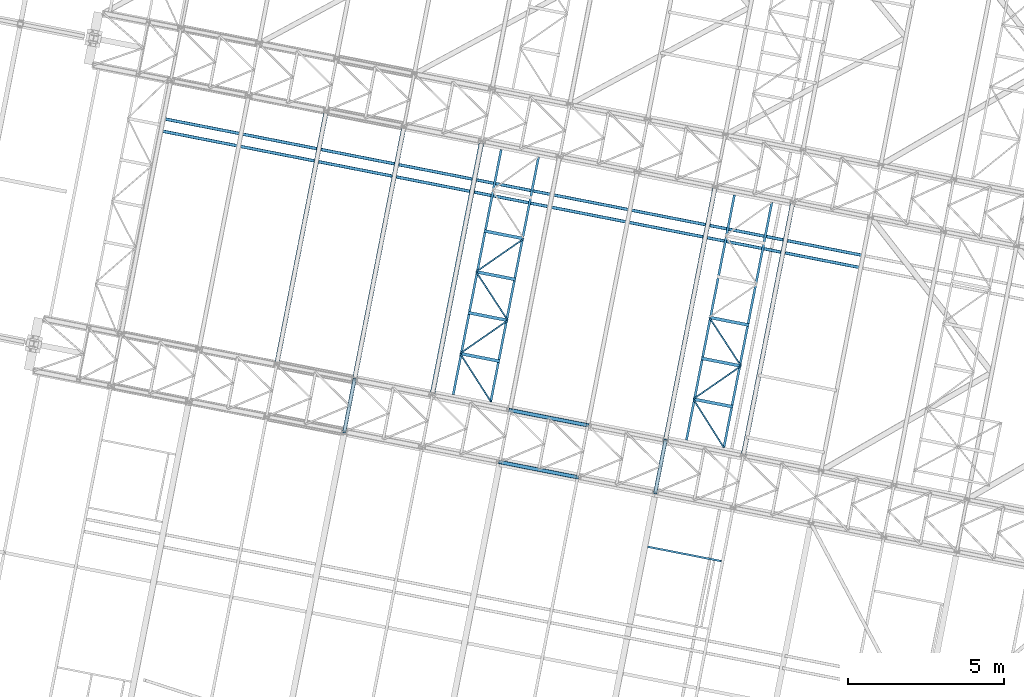
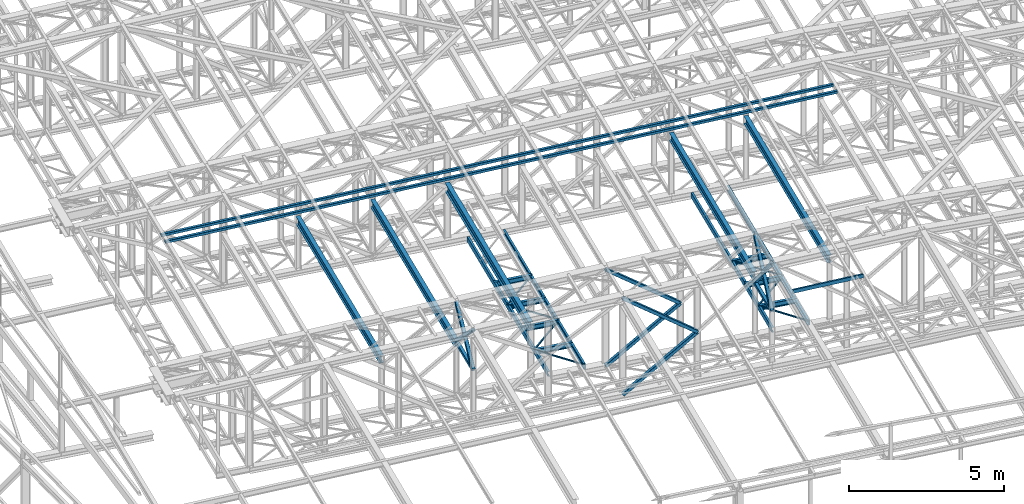
# One storey, part 44 of 215: 28 beams, 8 members, 36 elements without a shape of their own.
"""IFC2X3 building model written with IfcOpenShell, lengths in millimetres."""

from ifc_helpers import new_model, si_unit, frame, origin_with_axes, origin_2d_with_axis, place, context, subcontext, project, spatial, hollow_rectangle, i_section, u_section, extrude, material, type_object, element, aggregate, save


model = new_model("IFC2X3")

# Units and contexts
model_context = context("Model", 3, precision=1e-05, world=origin_with_axes())
body_context = subcontext(model_context, "Body", "Model", "MODEL_VIEW")
ifc_project = project(units=[si_unit("LENGTHUNIT", "METRE", prefix="MILLI"), si_unit("AREAUNIT", "SQUARE_METRE"), si_unit("VOLUMEUNIT", "CUBIC_METRE"), si_unit("MASSUNIT", "GRAM", prefix="KILO"), si_unit("TIMEUNIT", "SECOND"), si_unit("PLANEANGLEUNIT", "RADIAN"), si_unit("SOLIDANGLEUNIT", "STERADIAN"), si_unit("THERMODYNAMICTEMPERATUREUNIT", "DEGREE_CELSIUS"), si_unit("LUMINOUSINTENSITYUNIT", "LUMEN")], contexts=[model_context])

# Site, building, storey
site_placement = place(None, origin_with_axes())
site = spatial("IfcSite", under=ifc_project, at=site_placement, CompositionType="ELEMENT")
building_placement = place(site_placement, origin_with_axes())
building = spatial("IfcBuilding", under=site, at=building_placement, Name="Undefined", CompositionType="ELEMENT")
storey_placement = place(building_placement, origin_with_axes())
storey = spatial("IfcBuildingStorey", under=building, at=storey_placement, Name="Undefined", CompositionType="ELEMENT", Elevation=0.0)

# Assembly, beam
assembly_1_placement = place(storey_placement, origin_with_axes())
assembly_1 = element("IfcElementAssembly", 1, at=assembly_1_placement, inside=storey, Name="Steel Assembly", AssemblyPlace="NOTDEFINED", PredefinedType="RIGID_FRAME")
ifc_material_1 = material(Name="STEEL/S275JR")
beam_type_1 = type_object("IfcBeamType", PredefinedType="NOTDEFINED")
beam_1_placement = place(assembly_1_placement, frame((52219.5197880456, 20363.2867961429, 10796.000001022), z_axis=(0.981422364268518, -0.191859461052493, -0.000300197000082615), x_axis=(0.191859470081235, 0.981422408415534, 0.0)))
beam_1 = element("IfcBeam", 2, at=beam_1_placement, type_object=beam_type_1, material=ifc_material_1, context=body_context, shape_type="SweptSolid", body=[
    extrude(hollow_rectangle(XDim=120.0, YDim=120.0, WallThickness=5.0, InnerFilletRadius=5.0, OuterFilletRadius=10.0, at=origin_2d_with_axis()), frame((1699.99999941724, 1.81898940354586e-12, 0.0), z_axis=(-1.0, 0.0, 0.0), x_axis=(-6.93889390390723e-18, -1.0, -3.46944695195361e-18)), (0.0, 0.0, 1.0), 1700.0),
])
aggregate(assembly_1, [beam_1])

assembly_2_placement = place(storey_placement, origin_with_axes())
assembly_2 = element("IfcElementAssembly", 3, at=assembly_2_placement, inside=storey, Name="Steel Assembly", AssemblyPlace="NOTDEFINED", PredefinedType="RIGID_FRAME")
beam_2_placement = place(assembly_2_placement, frame((62204.4132373242, 18411.3277748122, 10796.0000009114), z_axis=(0.981422364268518, -0.191859461052493, -0.000300197000082615), x_axis=(0.191859470081235, 0.981422408415534, 0.0)))
beam_2 = element("IfcBeam", 4, at=beam_2_placement, type_object=beam_type_1, material=ifc_material_1, context=body_context, shape_type="SweptSolid", body=[
    extrude(hollow_rectangle(XDim=120.0, YDim=120.0, WallThickness=5.0, InnerFilletRadius=5.0, OuterFilletRadius=10.0, at=origin_2d_with_axis()), frame((1699.99999941724, 1.81898940354586e-12, 0.0), z_axis=(-1.0, 0.0, 0.0), x_axis=(-6.93889390390723e-18, -1.0, -3.46944695195361e-18)), (0.0, 0.0, 1.0), 1700.0),
])
aggregate(assembly_2, [beam_2])

assembly_3_placement = place(storey_placement, origin_with_axes())
assembly_3 = element("IfcElementAssembly", 5, at=assembly_3_placement, inside=storey, Name="Steel Assembly", AssemblyPlace="NOTDEFINED", PredefinedType="RIGID_FRAME")
beam_type_2 = type_object("IfcBeamType", PredefinedType="NOTDEFINED")
beam_3_placement = place(assembly_3_placement, frame((46407.8596790011, 30413.6755981437, 12020.0732186294), z_axis=(0.0304072880144601, -0.0059443590028274, -0.99951991547525), x_axis=(0.980943093982696, -0.191809039996616, 0.0309828749994535)))
beam_3 = element("IfcBeam", 6, at=beam_3_placement, type_object=beam_type_2, material=ifc_material_1, context=body_context, shape_type="SweptSolid", body=[
    extrude(hollow_rectangle(XDim=100.0, YDim=100.0, WallThickness=5.0, InnerFilletRadius=5.0, OuterFilletRadius=10.0, at=origin_2d_with_axis()), frame((22902.816814498, -7.45768641912541e-12, 0.0), z_axis=(-1.0, 0.0, 0.0), x_axis=(-6.93889390390723e-18, -1.0, -3.46944695195361e-18)), (0.0, 0.0, 1.0), 22902.8),
])
aggregate(assembly_3, [beam_3])

assembly_4_placement = place(storey_placement, origin_with_axes())
assembly_4 = element("IfcElementAssembly", 7, at=assembly_4_placement, inside=storey, Name="Steel Assembly", AssemblyPlace="NOTDEFINED", PredefinedType="RIGID_FRAME")
beam_4_placement = place(assembly_4_placement, frame((46331.0992129724, 30021.1098955661, 12020.0732185902), z_axis=(0.0304072880144601, -0.0059443590028274, -0.99951991547525), x_axis=(0.980943093982696, -0.191809039996616, 0.0309828749994535)))
beam_4 = element("IfcBeam", 8, at=beam_4_placement, type_object=beam_type_2, material=ifc_material_1, context=body_context, shape_type="SweptSolid", body=[
    extrude(hollow_rectangle(XDim=100.0, YDim=100.0, WallThickness=5.0, InnerFilletRadius=5.0, OuterFilletRadius=10.0, at=origin_2d_with_axis()), frame((22902.816814498, -7.45768641912541e-12, 0.0), z_axis=(-1.0, 0.0, 0.0), x_axis=(-6.93889390390723e-18, -1.0, -3.46944695195361e-18)), (0.0, 0.0, 1.0), 22902.8),
])
aggregate(assembly_4, [beam_4])

assembly_5_placement = place(storey_placement, origin_with_axes())
assembly_5 = element("IfcElementAssembly", 9, at=assembly_5_placement, inside=storey, Name="Steel Assembly", AssemblyPlace="NOTDEFINED", PredefinedType="RIGID_FRAME")
beam_type_3 = type_object("IfcBeamType", PredefinedType="NOTDEFINED")
beam_5_placement = place(assembly_5_placement, frame((55935.9362443765, 22873.5578027665, 8745.0), z_axis=(0.0, 0.0, -1.0), x_axis=(0.538159780693369, -0.842842838519771, 0.0)))
beam_5 = element("IfcBeam", 10, at=beam_5_placement, type_object=beam_type_3, material=ifc_material_1, context=body_context, shape_type="SweptSolid", body=[
    extrude(hollow_rectangle(XDim=50.0, YDim=50.0, WallThickness=3.0, InnerFilletRadius=3.0, OuterFilletRadius=6.0, at=origin_2d_with_axis()), frame((1829.52275494059, 0.0, 0.0), z_axis=(-1.0, 0.0, 0.0), x_axis=(-6.93889390390723e-18, -1.0, -3.46944695195361e-18)), (0.0, 0.0, 1.0), 1829.5),
])
aggregate(assembly_5, [beam_5])

assembly_6_placement = place(storey_placement, origin_with_axes())
assembly_6 = element("IfcElementAssembly", 11, at=assembly_6_placement, inside=storey, Name="Steel Assembly", AssemblyPlace="NOTDEFINED", PredefinedType="RIGID_FRAME")
beam_6_placement = place(assembly_6_placement, frame((57467.6126150394, 23935.7198777264, 8745.0), z_axis=(0.0, 0.0, -1.0), x_axis=(-0.821747337666729, -0.569852009768889, 0.0)))
beam_6 = element("IfcBeam", 12, at=beam_6_placement, type_object=beam_type_3, material=ifc_material_1, context=body_context, shape_type="SweptSolid", body=[
    extrude(hollow_rectangle(XDim=50.0, YDim=50.0, WallThickness=3.0, InnerFilletRadius=3.0, OuterFilletRadius=6.0, at=origin_2d_with_axis()), frame((1863.9261728348, 1.03468687664132e-13, 0.0), z_axis=(-1.0, 0.0, 0.0), x_axis=(-6.93889390390723e-18, -1.0, -3.46944695195361e-18)), (0.0, 0.0, 1.0), 1863.9),
])
aggregate(assembly_6, [beam_6])

assembly_7_placement = place(storey_placement, origin_with_axes())
assembly_7 = element("IfcElementAssembly", 13, at=assembly_7_placement, inside=storey, Name="Steel Assembly", AssemblyPlace="NOTDEFINED", PredefinedType="RIGID_FRAME")
beam_7_placement = place(assembly_7_placement, frame((56449.5868708495, 25497.0795917, 8745.0), z_axis=(0.0, 0.0, -1.0), x_axis=(0.54617279813842, -0.837672534212295, 0.0)))
beam_7 = element("IfcBeam", 14, at=beam_7_placement, type_object=beam_type_3, material=ifc_material_1, context=body_context, shape_type="SweptSolid", body=[
    extrude(hollow_rectangle(XDim=50.0, YDim=50.0, WallThickness=3.0, InnerFilletRadius=3.0, OuterFilletRadius=6.0, at=origin_2d_with_axis()), frame((1863.92611772227, 0.0, 1.81898940354586e-12), z_axis=(-1.0, 0.0, 0.0), x_axis=(-6.93889390390723e-18, -1.0, -3.46944695195361e-18)), (0.0, 0.0, 1.0), 1863.9),
])
aggregate(assembly_7, [beam_7])

assembly_8_placement = place(storey_placement, origin_with_axes())
assembly_8 = element("IfcElementAssembly", 15, at=assembly_8_placement, inside=storey, Name="Steel Assembly", AssemblyPlace="NOTDEFINED", PredefinedType="RIGID_FRAME")
beam_8_placement = place(assembly_8_placement, frame((57980.8309690882, 26558.5769034106, 8745.0), z_axis=(0.0, 0.0, -1.0), x_axis=(-0.821839062095499, -0.5697197170662, 0.0)))
beam_8 = element("IfcBeam", 16, at=beam_8_placement, type_object=beam_type_3, material=ifc_material_1, context=body_context, shape_type="SweptSolid", body=[
    extrude(hollow_rectangle(XDim=50.0, YDim=50.0, WallThickness=3.0, InnerFilletRadius=3.0, OuterFilletRadius=6.0, at=origin_2d_with_axis()), frame((1863.19216164478, 0.0, 0.0), z_axis=(-1.0, 0.0, 0.0), x_axis=(-6.93889390390723e-18, -1.0, -3.46944695195361e-18)), (0.0, 0.0, 1.0), 1863.2),
])
aggregate(assembly_8, [beam_8])

assembly_9_placement = place(storey_placement, origin_with_axes())
assembly_9 = element("IfcElementAssembly", 17, at=assembly_9_placement, inside=storey, Name="Steel Assembly", AssemblyPlace="NOTDEFINED", PredefinedType="RIGID_FRAME")
beam_9_placement = place(assembly_9_placement, frame((63422.3085909244, 21410.0377418613, 8745.0), z_axis=(0.0, 0.0, -1.0), x_axis=(0.53287875690889, -0.846191603855319, 0.0)))
beam_9 = element("IfcBeam", 18, at=beam_9_placement, type_object=beam_type_3, material=ifc_material_1, context=body_context, shape_type="SweptSolid", body=[
    extrude(hollow_rectangle(XDim=50.0, YDim=50.0, WallThickness=3.0, InnerFilletRadius=3.0, OuterFilletRadius=6.0, at=origin_2d_with_axis()), frame((1835.47534354543, 0.0, 0.0), z_axis=(-1.0, 0.0, 0.0), x_axis=(-6.93889390390723e-18, -1.0, -3.46944695195361e-18)), (0.0, 0.0, 1.0), 1835.5),
])
aggregate(assembly_9, [beam_9])

assembly_10_placement = place(storey_placement, origin_with_axes())
assembly_10 = element("IfcElementAssembly", 19, at=assembly_10_placement, inside=storey, Name="Steel Assembly", AssemblyPlace="NOTDEFINED", PredefinedType="RIGID_FRAME")
beam_10_placement = place(assembly_10_placement, frame((64954.8968461689, 22472.0414317465, 8745.0), z_axis=(0.0, 0.0, -1.0), x_axis=(-0.821945876331178, -0.56956560322949, 0.0)))
beam_10 = element("IfcBeam", 20, at=beam_10_placement, type_object=beam_type_3, material=ifc_material_1, context=body_context, shape_type="SweptSolid", body=[
    extrude(hollow_rectangle(XDim=50.0, YDim=50.0, WallThickness=3.0, InnerFilletRadius=3.0, OuterFilletRadius=6.0, at=origin_2d_with_axis()), frame((1864.58536882556, 0.0, 0.0), z_axis=(-1.0, 0.0, 0.0), x_axis=(-6.93889390390723e-18, -1.0, -3.46944695195361e-18)), (0.0, 0.0, 1.0), 1864.6),
])
aggregate(assembly_10, [beam_10])

assembly_11_placement = place(storey_placement, origin_with_axes())
assembly_11 = element("IfcElementAssembly", 21, at=assembly_11_placement, inside=storey, Name="Steel Assembly", AssemblyPlace="NOTDEFINED", PredefinedType="RIGID_FRAME")
beam_11_placement = place(assembly_11_placement, frame((63935.9192699006, 24033.5673808455, 8745.0), z_axis=(0.0, 0.0, -1.0), x_axis=(0.546490170770853, -0.837465517648843, 0.0)))
beam_11 = element("IfcBeam", 22, at=beam_11_placement, type_object=beam_type_3, material=ifc_material_1, context=body_context, shape_type="SweptSolid", body=[
    extrude(hollow_rectangle(XDim=50.0, YDim=50.0, WallThickness=3.0, InnerFilletRadius=3.0, OuterFilletRadius=6.0, at=origin_2d_with_axis()), frame((1864.58536882556, 0.0, 0.0), z_axis=(-1.0, 0.0, 0.0), x_axis=(-6.93889390390723e-18, -1.0, -3.46944695195361e-18)), (0.0, 0.0, 1.0), 1864.6),
])
aggregate(assembly_11, [beam_11])

assembly_12_placement = place(storey_placement, origin_with_axes())
assembly_12 = element("IfcElementAssembly", 23, at=assembly_12_placement, inside=storey, Name="Steel Assembly", AssemblyPlace="NOTDEFINED", PredefinedType="RIGID_FRAME")
ifc_material_2 = material(Name="STEEL/S235JR")
beam_type_4 = type_object("IfcBeamType", Name="UPN140", PredefinedType="NOTDEFINED")
beam_12_placement = place(assembly_12_placement, frame((64320.2677545784, 16207.585553462, 12769.5771242344), z_axis=(-0.0304080349967745, 0.00594450299936818, 0.999519891893966), x_axis=(-0.980947279001733, 0.191787511000338, -0.0309836480000548)))
beam_12 = element("IfcBeam", 24, at=beam_12_placement, type_object=beam_type_4, material=ifc_material_2, ObjectType="UPN140", context=body_context, shape_type="SweptSolid", body=[
    extrude(u_section(Depth=140.0, FlangeWidth=60.0, WebThickness=7.0, FlangeThickness=10.0, FilletRadius=10.0, EdgeRadius=5.0, FlangeSlope=0.0798299857122373, at=origin_2d_with_axis()), frame((2404.26612991932, -3.62067344519824e-12, -8.34147379613389e-15), z_axis=(-1.0, 0.0, 0.0), x_axis=(-6.93889390390723e-18, -1.0, -3.46944695195361e-18)), (0.0, 0.0, 1.0), 2404.3),
])
aggregate(assembly_12, [beam_12])

assembly_13_placement = place(storey_placement, origin_with_axes())
assembly_13 = element("IfcElementAssembly", 25, at=assembly_13_placement, inside=storey, Name="Steel Assembly", AssemblyPlace="NOTDEFINED", PredefinedType="RIGID_FRAME")
beam_type_5 = type_object("IfcBeamType", Name="UPN200", PredefinedType="NOTDEFINED")
beam_13_placement = place(assembly_13_placement, frame((57255.4686469135, 29418.0296462488, 8670.00000003358), z_axis=(0.0, 0.0, -1.0), x_axis=(-0.192138740064459, -0.981367772329233, 0.0)))
beam_13 = element("IfcBeam", 26, at=beam_13_placement, type_object=beam_type_5, material=ifc_material_1, ObjectType="UPN200", context=body_context, shape_type="SweptSolid", body=[
    extrude(u_section(Depth=200.0, FlangeWidth=75.0, WebThickness=8.5, FlangeThickness=11.5, FilletRadius=11.5, EdgeRadius=6.0, FlangeSlope=0.0798299857122373, at=origin_2d_with_axis()), frame((8012.73300634067, 0.0, 0.0), z_axis=(-1.0, 0.0, 0.0), x_axis=(-6.93889390390723e-18, -1.0, -3.46944695195361e-18)), (0.0, 0.0, 1.0), 8012.7),
])
aggregate(assembly_13, [beam_13])

assembly_14_placement = place(storey_placement, origin_with_axes())
assembly_14 = element("IfcElementAssembly", 27, at=assembly_14_placement, inside=storey, Name="Steel Assembly", AssemblyPlace="NOTDEFINED", PredefinedType="RIGID_FRAME")
beam_14_placement = place(assembly_14_placement, frame((56918.1647920204, 21319.5700001863, 8670.00000000009), z_axis=(0.0, 0.0, -1.0), x_axis=(0.19178870802505, 0.981436239128188, 0.0)))
beam_14 = element("IfcBeam", 28, at=beam_14_placement, type_object=beam_type_5, material=ifc_material_1, ObjectType="UPN200", context=body_context, shape_type="SweptSolid", body=[
    extrude(u_section(Depth=200.0, FlangeWidth=75.0, WebThickness=8.5, FlangeThickness=11.5, FilletRadius=11.5, EdgeRadius=6.0, FlangeSlope=0.0798299857122373, at=origin_2d_with_axis()), frame((8019.9954338182, 0.0, 0.0), z_axis=(-1.0, 0.0, 0.0), x_axis=(-6.93889390390723e-18, -1.0, -3.46944695195361e-18)), (0.0, 0.0, 1.0), 8020.0),
])
aggregate(assembly_14, [beam_14])

assembly_15_placement = place(storey_placement, origin_with_axes())
assembly_15 = element("IfcElementAssembly", 29, at=assembly_15_placement, inside=storey, Name="Steel Assembly", AssemblyPlace="NOTDEFINED", PredefinedType="RIGID_FRAME")
beam_15_placement = place(assembly_15_placement, frame((64743.136689549, 27961.6571970074, 8670.00000003358), z_axis=(0.0, 0.0, -1.0), x_axis=(-0.192123795048203, -0.981370698246221, 0.0)))
beam_15 = element("IfcBeam", 30, at=beam_15_placement, type_object=beam_type_5, material=ifc_material_1, ObjectType="UPN200", context=body_context, shape_type="SweptSolid", body=[
    extrude(u_section(Depth=200.0, FlangeWidth=75.0, WebThickness=8.5, FlangeThickness=11.5, FilletRadius=11.5, EdgeRadius=6.0, FlangeSlope=0.0798299857122373, at=origin_2d_with_axis()), frame((8019.99583950526, -7.27595761418343e-12, -1.81898940354586e-12), z_axis=(-1.0, 0.0, 0.0), x_axis=(-6.93889390390723e-18, -1.0, -3.46944695195361e-18)), (0.0, 0.0, 1.0), 8020.0),
])
aggregate(assembly_15, [beam_15])

assembly_16_placement = place(storey_placement, origin_with_axes())
assembly_16 = element("IfcElementAssembly", 31, at=assembly_16_placement, inside=storey, Name="Steel Assembly", AssemblyPlace="NOTDEFINED", PredefinedType="RIGID_FRAME")
beam_16_placement = place(assembly_16_placement, frame((64404.5652369769, 19856.0573986768, 8670.00000000018), z_axis=(0.0, 0.0, -1.0), x_axis=(0.192121907938422, 0.98137106768546, 0.0)))
beam_16 = element("IfcBeam", 32, at=beam_16_placement, type_object=beam_type_5, material=ifc_material_1, ObjectType="UPN200", context=body_context, shape_type="SweptSolid", body=[
    extrude(u_section(Depth=200.0, FlangeWidth=75.0, WebThickness=8.5, FlangeThickness=11.5, FilletRadius=11.5, EdgeRadius=6.0, FlangeSlope=0.0798299857122373, at=origin_2d_with_axis()), frame((8019.99583950526, -7.27595761418343e-12, -1.81898940354586e-12), z_axis=(-1.0, 0.0, 0.0), x_axis=(-6.93889390390723e-18, -1.0, -3.46944695195361e-18)), (0.0, 0.0, 1.0), 8020.0),
])
aggregate(assembly_16, [beam_16])

# Assembly, member
assembly_17_placement = place(storey_placement, origin_with_axes())
assembly_17 = element("IfcElementAssembly", 33, at=assembly_17_placement, inside=storey, Name="Steel Assembly", AssemblyPlace="NOTDEFINED", PredefinedType="RIGID_FRAME")
member_type = type_object("IfcMemberType", PredefinedType="NOTDEFINED")
member_1_placement = place(assembly_17_placement, frame((52545.6808867303, 22031.70488996, 10796.0000010202), z_axis=(0.981461316285517, -0.191660209055757, 0.000221133000063429), x_axis=(-0.1413283100442, -0.722939399226104, 0.676302398211518)))
member_1 = element("IfcMember", 34, at=member_1_placement, type_object=member_type, material=ifc_material_1, context=body_context, shape_type="SweptSolid", body=[
    extrude(hollow_rectangle(XDim=120.0, YDim=120.0, WallThickness=5.0, InnerFilletRadius=5.0, OuterFilletRadius=10.0, at=origin_2d_with_axis()), frame((2307.82564529445, -1.28110058411315e-13, 8.31339197405457e-14), z_axis=(-1.0, 0.0, 0.0), x_axis=(-6.93889390390723e-18, -1.0, -3.46944695195361e-18)), (0.0, 0.0, 1.0), 2307.8),
])
aggregate(assembly_17, [member_1])

assembly_18_placement = place(storey_placement, origin_with_axes())
assembly_18 = element("IfcElementAssembly", 35, at=assembly_18_placement, inside=storey, Name="Steel Assembly", AssemblyPlace="NOTDEFINED", PredefinedType="RIGID_FRAME")
member_2_placement = place(assembly_18_placement, frame((52219.5197880456, 20363.2867961429, 10796.000001022), z_axis=(0.981461316285734, -0.1916602090558, -0.000221132000064958), x_axis=(0.141328309922255, 0.722939402602315, 0.67630239462797)))
member_2 = element("IfcMember", 36, at=member_2_placement, type_object=member_type, material=ifc_material_1, context=body_context, shape_type="SweptSolid", body=[
    extrude(hollow_rectangle(XDim=120.0, YDim=120.0, WallThickness=5.0, InnerFilletRadius=5.0, OuterFilletRadius=10.0, at=origin_2d_with_axis()), frame((2307.82564529445, -1.28110058411315e-13, 8.31339197405457e-14), z_axis=(-1.0, 0.0, 0.0), x_axis=(-6.93889390390723e-18, -1.0, -3.46944695195361e-18)), (0.0, 0.0, 1.0), 2307.8),
])
aggregate(assembly_18, [member_2])

assembly_19_placement = place(storey_placement, origin_with_axes())
assembly_19 = element("IfcElementAssembly", 37, at=assembly_19_placement, inside=storey, Name="Steel Assembly", AssemblyPlace="NOTDEFINED", PredefinedType="RIGID_FRAME")
member_3_placement = place(assembly_19_placement, frame((62530.5743359945, 20079.7458686253, 10796.0000009096), z_axis=(0.981465045882622, -0.191641130977078, 0.000201564999975286), x_axis=(-0.128822807021333, -0.658969764109112, 0.741055689122704)))
member_3 = element("IfcMember", 38, at=member_3_placement, type_object=member_type, material=ifc_material_1, context=body_context, shape_type="SweptSolid", body=[
    extrude(hollow_rectangle(XDim=120.0, YDim=120.0, WallThickness=5.0, InnerFilletRadius=5.0, OuterFilletRadius=10.0, at=origin_2d_with_axis()), frame((2531.85832868423, -6.99486487302401e-12, 7.33099579250614e-12), z_axis=(-1.0, 0.0, 0.0), x_axis=(-6.93889390390723e-18, -1.0, -3.46944695195361e-18)), (0.0, 0.0, 1.0), 2531.9),
])
aggregate(assembly_19, [member_3])

assembly_20_placement = place(storey_placement, origin_with_axes())
assembly_20 = element("IfcElementAssembly", 39, at=assembly_20_placement, inside=storey, Name="Steel Assembly", AssemblyPlace="NOTDEFINED", PredefinedType="RIGID_FRAME")
member_4_placement = place(assembly_20_placement, frame((62204.4132373242, 18411.3277748122, 10796.0000009114), z_axis=(0.981465045882622, -0.191641130977078, -0.000201564999975286), x_axis=(0.128822807951567, 0.658969767752257, 0.741055685721397)))
member_4 = element("IfcMember", 40, at=member_4_placement, type_object=member_type, material=ifc_material_1, context=body_context, shape_type="SweptSolid", body=[
    extrude(hollow_rectangle(XDim=120.0, YDim=120.0, WallThickness=5.0, InnerFilletRadius=5.0, OuterFilletRadius=10.0, at=origin_2d_with_axis()), frame((2531.85832868423, -6.99486487302401e-12, 7.33099579250614e-12), z_axis=(-1.0, 0.0, 0.0), x_axis=(-6.93889390390723e-18, -1.0, -3.46944695195361e-18)), (0.0, 0.0, 1.0), 2531.9),
])
aggregate(assembly_20, [member_4])

assembly_21_placement = place(storey_placement, origin_with_axes())
assembly_21 = element("IfcElementAssembly", 41, at=assembly_21_placement, inside=storey, Name="Steel Assembly", AssemblyPlace="NOTDEFINED", PredefinedType="RIGID_FRAME")
member_5_placement = place(assembly_21_placement, frame((57211.9675403584, 19387.3070754083, 8655.00000193396), z_axis=(0.587493472692391, -0.114849807939864, -0.801037415580578), x_axis=(0.786156070230782, -0.153686611045116, 0.598614282175727)))
member_5 = element("IfcMember", 42, at=member_5_placement, type_object=member_type, material=ifc_material_1, context=body_context, shape_type="SweptSolid", body=[
    extrude(hollow_rectangle(XDim=120.0, YDim=120.0, WallThickness=5.0, InnerFilletRadius=5.0, OuterFilletRadius=10.0, at=origin_2d_with_axis()), frame((3169.02675432624, -2.43384340210519e-14, 0.0), z_axis=(-1.0, 0.0, 0.0), x_axis=(-6.93889390390723e-18, -1.0, -3.46944695195361e-18)), (0.0, 0.0, 1.0), 3169.0),
])
aggregate(assembly_21, [member_5])

assembly_22_placement = place(storey_placement, origin_with_axes())
assembly_22 = element("IfcElementAssembly", 43, at=assembly_22_placement, inside=storey, Name="Steel Assembly", AssemblyPlace="NOTDEFINED", PredefinedType="RIGID_FRAME")
member_6_placement = place(assembly_22_placement, frame((57538.128632471, 21055.7251711604, 8655.00000193395), z_axis=(0.587493472692391, -0.114849807939864, -0.801037415580578), x_axis=(0.786156070230782, -0.153686611045116, 0.598614282175727)))
member_6 = element("IfcMember", 44, at=member_6_placement, type_object=member_type, material=ifc_material_1, context=body_context, shape_type="SweptSolid", body=[
    extrude(hollow_rectangle(XDim=120.0, YDim=120.0, WallThickness=5.0, InnerFilletRadius=5.0, OuterFilletRadius=10.0, at=origin_2d_with_axis()), frame((3169.02675432624, -2.43384340210519e-14, 0.0), z_axis=(-1.0, 0.0, 0.0), x_axis=(-6.93889390390723e-18, -1.0, -3.46944695195361e-18)), (0.0, 0.0, 1.0), 3169.0),
])
aggregate(assembly_22, [member_6])

assembly_23_placement = place(storey_placement, origin_with_axes())
assembly_23 = element("IfcElementAssembly", 45, at=assembly_23_placement, inside=storey, Name="Steel Assembly", AssemblyPlace="NOTDEFINED", PredefinedType="RIGID_FRAME")
member_7_placement = place(assembly_23_placement, frame((57216.6807866434, 19386.3856770367, 12449.5061705353), z_axis=(-0.5871579940314, 0.114784234006137, -0.80129274904285), x_axis=(0.786406660116399, -0.153735599022755, -0.598272455088553)))
member_7 = element("IfcMember", 46, at=member_7_placement, type_object=member_type, material=ifc_material_1, context=body_context, shape_type="SweptSolid", body=[
    extrude(hollow_rectangle(XDim=120.0, YDim=120.0, WallThickness=5.0, InnerFilletRadius=5.0, OuterFilletRadius=10.0, at=origin_2d_with_axis()), frame((3165.45158595242, -1.49800009052741e-13, -1.7571786170303e-13), z_axis=(-1.0, 0.0, 0.0), x_axis=(-6.93889390390723e-18, -1.0, -3.46944695195361e-18)), (0.0, 0.0, 1.0), 3165.5),
])
aggregate(assembly_23, [member_7])

assembly_24_placement = place(storey_placement, origin_with_axes())
assembly_24 = element("IfcElementAssembly", 47, at=assembly_24_placement, inside=storey, Name="Steel Assembly", AssemblyPlace="NOTDEFINED", PredefinedType="RIGID_FRAME")
member_8_placement = place(assembly_24_placement, frame((57542.8418787729, 21054.8037727855, 12449.5061705353), z_axis=(-0.5871579940314, 0.114784234006137, -0.80129274904285), x_axis=(0.786406660116399, -0.153735599022755, -0.598272455088553)))
member_8 = element("IfcMember", 48, at=member_8_placement, type_object=member_type, material=ifc_material_1, context=body_context, shape_type="SweptSolid", body=[
    extrude(hollow_rectangle(XDim=120.0, YDim=120.0, WallThickness=5.0, InnerFilletRadius=5.0, OuterFilletRadius=10.0, at=origin_2d_with_axis()), frame((3165.45158595242, -1.49800009052741e-13, -1.7571786170303e-13), z_axis=(-1.0, 0.0, 0.0), x_axis=(-6.93889390390723e-18, -1.0, -3.46944695195361e-18)), (0.0, 0.0, 1.0), 3165.5),
])
aggregate(assembly_24, [member_8])

# Assembly, beam
assembly_25_placement = place(storey_placement, origin_with_axes())
assembly_25 = element("IfcElementAssembly", 49, at=assembly_25_placement, inside=storey, Name="Steel Assembly", AssemblyPlace="NOTDEFINED", PredefinedType="RIGID_FRAME")
beam_type_6 = type_object("IfcBeamType", Name="IPE300", PredefinedType="NOTDEFINED")
beam_17_placement = place(assembly_25_placement, frame((65026.8034830354, 19591.755293955, 11119.0000001701), z_axis=(0.0, 0.0, 1.0), x_axis=(0.191859470081235, 0.981422408415534, 0.0)))
beam_17 = element("IfcBeam", 50, at=beam_17_placement, type_object=beam_type_6, material=ifc_material_1, Name="SUPPORT", ObjectType="IPE300", context=body_context, shape_type="SweptSolid", body=[
    extrude(i_section(OverallWidth=150.0, OverallDepth=300.0, WebThickness=7.099999905, FlangeThickness=10.69999981, FilletRadius=15.0, at=origin_2d_with_axis()), frame((8299.99526300685, 1.47838788079098e-11, -1.71639879146031e-21), z_axis=(-1.0, 0.0, 0.0), x_axis=(-6.93889390390723e-18, -1.0, -3.46944695195361e-18)), (0.0, 0.0, 1.0), 8300.0),
])
aggregate(assembly_25, [beam_17])

assembly_26_placement = place(storey_placement, origin_with_axes())
assembly_26 = element("IfcElementAssembly", 51, at=assembly_26_placement, inside=storey, Name="Steel Assembly", AssemblyPlace="NOTDEFINED", PredefinedType="RIGID_FRAME")
beam_18_placement = place(assembly_26_placement, frame((62530.5793760316, 20079.7451548864, 11040.1600001886), z_axis=(0.0, 0.0, 1.0), x_axis=(0.191859470081235, 0.981422408415534, 0.0)))
beam_18 = element("IfcBeam", 52, at=beam_18_placement, type_object=beam_type_6, material=ifc_material_1, Name="SUPPORT", ObjectType="IPE300", context=body_context, shape_type="SweptSolid", body=[
    extrude(i_section(OverallWidth=150.0, OverallDepth=300.0, WebThickness=7.099999905, FlangeThickness=10.69999981, FilletRadius=15.0, at=origin_2d_with_axis()), frame((8299.99526300685, 1.47838788079098e-11, -1.71639879146031e-21), z_axis=(-1.0, 0.0, 0.0), x_axis=(-6.93889390390723e-18, -1.0, -3.46944695195361e-18)), (0.0, 0.0, 1.0), 8300.0),
])
aggregate(assembly_26, [beam_18])

assembly_27_placement = place(storey_placement, origin_with_axes())
assembly_27 = element("IfcElementAssembly", 53, at=assembly_27_placement, inside=storey, Name="Steel Assembly", AssemblyPlace="NOTDEFINED", PredefinedType="RIGID_FRAME")
beam_19_placement = place(assembly_27_placement, frame((52545.6829558721, 22031.704597175, 10724.7800002627), z_axis=(0.0, 0.0, 1.0), x_axis=(0.191859470081235, 0.981422408415534, 0.0)))
beam_19 = element("IfcBeam", 54, at=beam_19_placement, type_object=beam_type_6, material=ifc_material_1, Name="SUPPORT", ObjectType="IPE300", context=body_context, shape_type="SweptSolid", body=[
    extrude(i_section(OverallWidth=150.0, OverallDepth=300.0, WebThickness=7.099999905, FlangeThickness=10.69999981, FilletRadius=15.0, at=origin_2d_with_axis()), frame((8299.99526300685, 1.47838788079098e-11, -1.71639879146031e-21), z_axis=(-1.0, 0.0, 0.0), x_axis=(-6.93889390390723e-18, -1.0, -3.46944695195361e-18)), (0.0, 0.0, 1.0), 8300.0),
])
aggregate(assembly_27, [beam_19])

assembly_28_placement = place(storey_placement, origin_with_axes())
assembly_28 = element("IfcElementAssembly", 55, at=assembly_28_placement, inside=storey, Name="Steel Assembly", AssemblyPlace="NOTDEFINED", PredefinedType="RIGID_FRAME")
beam_20_placement = place(assembly_28_placement, frame((50049.4588505286, 22519.6944578805, 10645.9400002812), z_axis=(0.0, 0.0, 1.0), x_axis=(0.191859470081235, 0.981422408415534, 0.0)))
beam_20 = element("IfcBeam", 56, at=beam_20_placement, type_object=beam_type_6, material=ifc_material_1, Name="SUPPORT", ObjectType="IPE300", context=body_context, shape_type="SweptSolid", body=[
    extrude(i_section(OverallWidth=150.0, OverallDepth=300.0, WebThickness=7.099999905, FlangeThickness=10.69999981, FilletRadius=15.0, at=origin_2d_with_axis()), frame((8299.99526300685, 1.47838788079098e-11, -1.71639879146031e-21), z_axis=(-1.0, 0.0, 0.0), x_axis=(-6.93889390390723e-18, -1.0, -3.46944695195361e-18)), (0.0, 0.0, 1.0), 8300.0),
])
aggregate(assembly_28, [beam_20])

assembly_29_placement = place(storey_placement, origin_with_axes())
assembly_29 = element("IfcElementAssembly", 57, at=assembly_29_placement, inside=storey, Name="Steel Assembly", AssemblyPlace="NOTDEFINED", PredefinedType="RIGID_FRAME")
beam_type_7 = type_object("IfcBeamType", Name="IPE200", PredefinedType="NOTDEFINED")
beam_21_placement = place(assembly_29_placement, frame((64954.8968461689, 22472.0414317465, 8670.00000000005), z_axis=(0.0, 0.0, -1.0), x_axis=(-0.981370698434766, 0.192123794085116, 0.0)))
beam_21 = element("IfcBeam", 58, at=beam_21_placement, type_object=beam_type_7, material=ifc_material_1, ObjectType="IPE200", context=body_context, shape_type="SweptSolid", body=[
    extrude(i_section(OverallWidth=100.0, OverallDepth=200.0, WebThickness=5.599999905, FlangeThickness=8.5, FilletRadius=12.0, at=origin_2d_with_axis()), frame((1300.00102692207, 3.60822768031308e-14, 0.0), z_axis=(-1.0, 0.0, 0.0), x_axis=(-6.93889390390723e-18, -1.0, -3.46944695195361e-18)), (0.0, 0.0, 1.0), 1300.0),
])
aggregate(assembly_29, [beam_21])

assembly_30_placement = place(storey_placement, origin_with_axes())
assembly_30 = element("IfcElementAssembly", 59, at=assembly_30_placement, inside=storey, Name="Steel Assembly", AssemblyPlace="NOTDEFINED", PredefinedType="RIGID_FRAME")
beam_22_placement = place(assembly_30_placement, frame((57211.7087542816, 22623.7785751644, 8670.00000000005), z_axis=(0.0, 0.0, -1.0), x_axis=(-0.981367778018941, 0.192138711003709, 0.0)))
beam_22 = element("IfcBeam", 60, at=beam_22_placement, type_object=beam_type_7, material=ifc_material_1, ObjectType="IPE200", context=body_context, shape_type="SweptSolid", body=[
    extrude(i_section(OverallWidth=100.0, OverallDepth=200.0, WebThickness=5.599999905, FlangeThickness=8.5, FilletRadius=12.0, at=origin_2d_with_axis()), frame((1299.99429213023, 0.0, -1.81898940354586e-12), z_axis=(-1.0, 0.0, 0.0), x_axis=(-6.93889390390723e-18, -1.0, -3.46944695195361e-18)), (0.0, 0.0, 1.0), 1300.0),
])
aggregate(assembly_30, [beam_22])

assembly_31_placement = place(storey_placement, origin_with_axes())
assembly_31 = element("IfcElementAssembly", 61, at=assembly_31_placement, inside=storey, Name="Steel Assembly", AssemblyPlace="NOTDEFINED", PredefinedType="RIGID_FRAME")
beam_23_placement = place(assembly_31_placement, frame((57468.5340675181, 23935.5394696312, 8670.00000000005), z_axis=(0.0, 0.0, -1.0), x_axis=(-0.981367778018941, 0.192138711003709, 0.0)))
beam_23 = element("IfcBeam", 62, at=beam_23_placement, type_object=beam_type_7, material=ifc_material_1, ObjectType="IPE200", context=body_context, shape_type="SweptSolid", body=[
    extrude(i_section(OverallWidth=100.0, OverallDepth=200.0, WebThickness=5.599999905, FlangeThickness=8.5, FilletRadius=12.0, at=origin_2d_with_axis()), frame((1299.99429213023, 0.0, -1.81898940354586e-12), z_axis=(-1.0, 0.0, 0.0), x_axis=(-6.93889390390723e-18, -1.0, -3.46944695195361e-18)), (0.0, 0.0, 1.0), 1300.0),
])
aggregate(assembly_31, [beam_23])

assembly_32_placement = place(storey_placement, origin_with_axes())
assembly_32 = element("IfcElementAssembly", 63, at=assembly_32_placement, inside=storey, Name="Steel Assembly", AssemblyPlace="NOTDEFINED", PredefinedType="RIGID_FRAME")
beam_24_placement = place(assembly_32_placement, frame((57725.3593807546, 25247.3003640979, 8670.00000000005), z_axis=(0.0, 0.0, -1.0), x_axis=(-0.981367778018941, 0.192138711003709, 0.0)))
beam_24 = element("IfcBeam", 64, at=beam_24_placement, type_object=beam_type_7, material=ifc_material_1, ObjectType="IPE200", context=body_context, shape_type="SweptSolid", body=[
    extrude(i_section(OverallWidth=100.0, OverallDepth=200.0, WebThickness=5.599999905, FlangeThickness=8.5, FilletRadius=12.0, at=origin_2d_with_axis()), frame((1299.99429213023, 0.0, -1.81898940354586e-12), z_axis=(-1.0, 0.0, 0.0), x_axis=(-6.93889390390723e-18, -1.0, -3.46944695195361e-18)), (0.0, 0.0, 1.0), 1300.0),
])
aggregate(assembly_32, [beam_24])

assembly_33_placement = place(storey_placement, origin_with_axes())
assembly_33 = element("IfcElementAssembly", 65, at=assembly_33_placement, inside=storey, Name="Steel Assembly", AssemblyPlace="NOTDEFINED", PredefinedType="RIGID_FRAME")
beam_25_placement = place(assembly_33_placement, frame((57982.1846939911, 26559.0612585647, 8670.00000000005), z_axis=(0.0, 0.0, -1.0), x_axis=(-0.981367778018941, 0.192138711003709, 0.0)))
beam_25 = element("IfcBeam", 66, at=beam_25_placement, type_object=beam_type_7, material=ifc_material_1, ObjectType="IPE200", context=body_context, shape_type="SweptSolid", body=[
    extrude(i_section(OverallWidth=100.0, OverallDepth=200.0, WebThickness=5.599999905, FlangeThickness=8.5, FilletRadius=12.0, at=origin_2d_with_axis()), frame((1299.99429213023, 0.0, -1.81898940354586e-12), z_axis=(-1.0, 0.0, 0.0), x_axis=(-6.93889390390723e-18, -1.0, -3.46944695195361e-18)), (0.0, 0.0, 1.0), 1300.0),
])
aggregate(assembly_33, [beam_25])

assembly_34_placement = place(storey_placement, origin_with_axes())
assembly_34 = element("IfcElementAssembly", 67, at=assembly_34_placement, inside=storey, Name="Steel Assembly", AssemblyPlace="NOTDEFINED", PredefinedType="RIGID_FRAME")
beam_26_placement = place(assembly_34_placement, frame((64697.1261799828, 21162.3223816731, 8670.00000000005), z_axis=(0.0, 0.0, -1.0), x_axis=(-0.981639307696328, 0.190746610940992, 0.0)))
beam_26 = element("IfcBeam", 68, at=beam_26_placement, type_object=beam_type_7, material=ifc_material_1, ObjectType="IPE200", context=body_context, shape_type="SweptSolid", body=[
    extrude(i_section(OverallWidth=100.0, OverallDepth=200.0, WebThickness=5.599999905, FlangeThickness=8.5, FilletRadius=12.0, at=origin_2d_with_axis()), frame((1298.66192099631, 0.0, 0.0), z_axis=(-1.0, 0.0, 0.0), x_axis=(-6.93889390390723e-18, -1.0, -3.46944695195361e-18)), (0.0, 0.0, 1.0), 1298.7),
])
aggregate(assembly_34, [beam_26])

assembly_35_placement = place(storey_placement, origin_with_axes())
assembly_35 = element("IfcElementAssembly", 69, at=assembly_35_placement, inside=storey, Name="Steel Assembly", AssemblyPlace="NOTDEFINED", PredefinedType="RIGID_FRAME")
beam_27_placement = place(assembly_35_placement, frame((65211.702185657, 23783.8062512386, 8670.00000000005), z_axis=(0.0, 0.0, -1.0), x_axis=(-0.981370698434766, 0.192123794085116, 0.0)))
beam_27 = element("IfcBeam", 70, at=beam_27_placement, type_object=beam_type_7, material=ifc_material_1, ObjectType="IPE200", context=body_context, shape_type="SweptSolid", body=[
    extrude(i_section(OverallWidth=100.0, OverallDepth=200.0, WebThickness=5.599999905, FlangeThickness=8.5, FilletRadius=12.0, at=origin_2d_with_axis()), frame((1300.00102692207, 3.60822768031308e-14, 0.0), z_axis=(-1.0, 0.0, 0.0), x_axis=(-6.93889390390723e-18, -1.0, -3.46944695195361e-18)), (0.0, 0.0, 1.0), 1300.0),
])
aggregate(assembly_35, [beam_27])

assembly_36_placement = place(storey_placement, origin_with_axes())
assembly_36 = element("IfcElementAssembly", 71, at=assembly_36_placement, inside=storey, Name="Steel Assembly", AssemblyPlace="NOTDEFINED", PredefinedType="RIGID_FRAME")
beam_type_8 = type_object("IfcBeamType", Name="IPE330", PredefinedType="NOTDEFINED")
beam_28_placement = place(assembly_36_placement, frame((55041.9070611148, 21543.7147364928, 10788.6300003659), z_axis=(0.0, 0.0, 1.0), x_axis=(0.191859470081235, 0.981422408415534, 0.0)))
beam_28 = element("IfcBeam", 72, at=beam_28_placement, type_object=beam_type_8, material=ifc_material_1, Name="SUPPORT", ObjectType="IPE330", context=body_context, shape_type="SweptSolid", body=[
    extrude(i_section(OverallWidth=160.0, OverallDepth=330.0, WebThickness=7.5, FlangeThickness=11.5, FilletRadius=18.0, at=origin_2d_with_axis()), frame((8299.99526300685, 1.47838788079098e-11, -1.71639879146031e-21), z_axis=(-1.0, 0.0, 0.0), x_axis=(-6.93889390390723e-18, -1.0, -3.46944695195361e-18)), (0.0, 0.0, 1.0), 8300.0),
])
aggregate(assembly_36, [beam_28])

save(model, "model.ifc")
